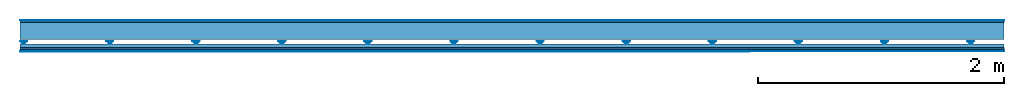
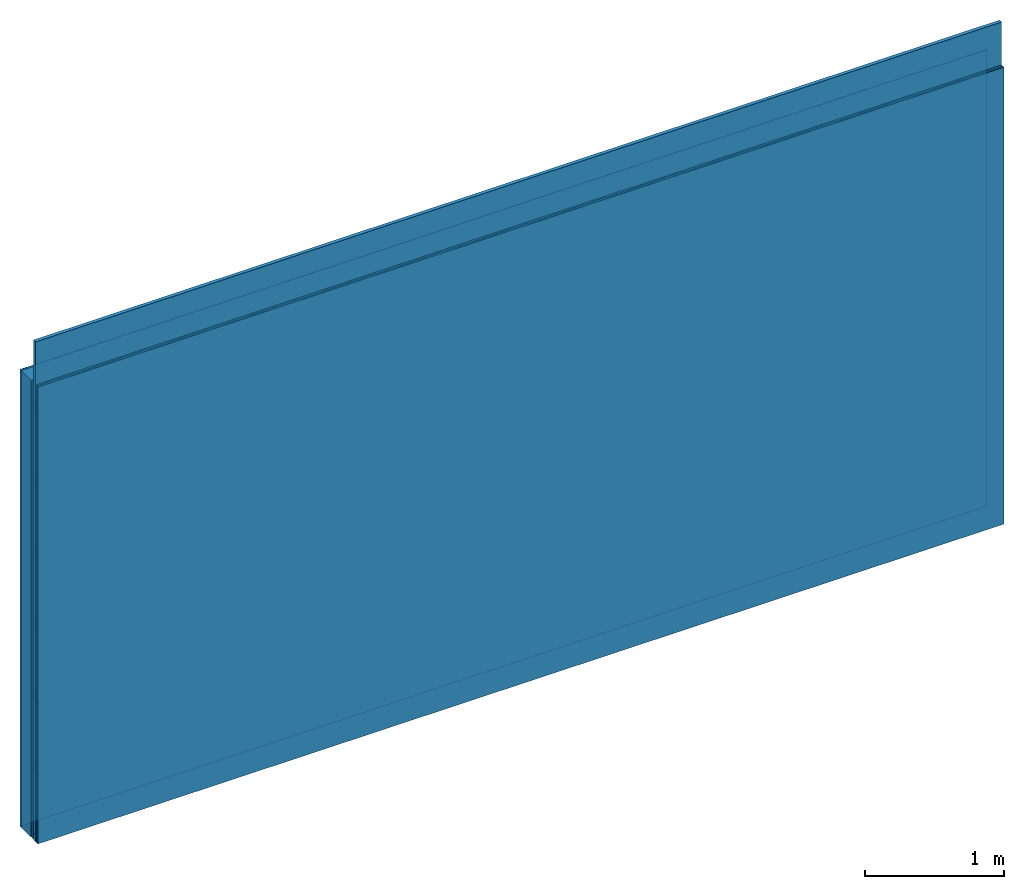
# One storey: 5 plates, 4 members, 1 element without a shape of its own.
"""IFC4 building model written with IfcOpenShell, lengths in metres."""

import ifcopenshell
import ifcopenshell.guid

model = None  # the IFC model being written
_history = None  # IfcOwnerHistory: only IFC2X3 demands one
_inside = {}  # id of a spatial element -> (the spatial element, [elements in it])
_under = {}  # id of a project, library or spatial element -> (it, [spatial elements below it])
_declared = {}  # id of a project -> (the project, [libraries it declares])
_typed = {}  # id of a type object -> (the type object, [elements of that type])
_made_of = {}  # id of a material, layer set ... -> (it, [elements and type objects made of it])


def new_model(schema):
    """Start an empty IFC model of exactly this schema.

    Asked for "IFC4X3", IfcOpenShell would pick the latest addendum, in which some entities
    have other attributes; the version numbers below select the first issue.
    IFC2X3 requires an IfcOwnerHistory on every rooted entity: one is made here for all.
    """
    global model, _history
    if schema == "IFC4X3":
        model = ifcopenshell.file(schema_version=(4, 3, 0, 0))
    else:
        model = ifcopenshell.file(schema=schema)
    _inside.clear()
    _under.clear()
    _declared.clear()
    _typed.clear()
    _made_of.clear()
    _history = None
    if model.schema == "IFC2X3":
        org = make("IfcOrganization", Name="unknown")
        user = make(
            "IfcPersonAndOrganization",
            ThePerson=make("IfcPerson", FamilyName="unknown"),
            TheOrganization=org,
        )
        app = make(
            "IfcApplication",
            ApplicationDeveloper=org,
            Version="unknown",
            ApplicationFullName="unknown",
            ApplicationIdentifier="unknown",
        )
        _history = make(
            "IfcOwnerHistory",
            OwningUser=user,
            OwningApplication=app,
            ChangeAction="ADDED",
            CreationDate=0,
        )
    return model


def make(cls, **values):
    """One entity of the class cls with the attributes given. An attribute that is None is left unset."""
    return model.create_entity(
        cls, **{name: value for name, value in values.items() if value is not None}
    )


def rooted(cls, **values):
    """An entity with a GlobalId (a new one), such as an element, a storey or a relation."""
    return make(cls, GlobalId=ifcopenshell.guid.new(), OwnerHistory=_history, **values)


def si_unit(unit_type, name, prefix=None):
    """IfcSIUnit, for example si_unit("LENGTHUNIT", "METRE", prefix="MILLI")."""
    return make("IfcSIUnit", UnitType=unit_type, Prefix=prefix, Name=name)


def derived_unit(unit_type, elements):
    """IfcDerivedUnit: a product of units, each with its exponent."""
    return make(
        "IfcDerivedUnit",
        Elements=[
            make("IfcDerivedUnitElement", Unit=unit, Exponent=power)
            for unit, power in elements
        ],
        UnitType=unit_type,
    )


def assignment(units):
    """IfcUnitAssignment: the units of a project."""
    return None if units is None else make("IfcUnitAssignment", Units=units)


def point(xyz):
    """IfcCartesianPoint."""
    return None if xyz is None else make("IfcCartesianPoint", Coordinates=xyz)


def direction(xyz):
    """IfcDirection."""
    return None if xyz is None else make("IfcDirection", DirectionRatios=xyz)


def frame(location, z_axis=None, x_axis=None):
    """IfcAxis2Placement3D, a coordinate frame: its origin and axes. An axis left out is left unset."""
    return make(
        "IfcAxis2Placement3D",
        Location=point(location),
        Axis=direction(z_axis),
        RefDirection=direction(x_axis),
    )


def frame_2d(location, x_axis=None):
    """IfcAxis2Placement2D, a coordinate frame in the plane: its origin and x axis."""
    return make(
        "IfcAxis2Placement2D", Location=point(location), RefDirection=direction(x_axis)
    )


def origin():
    """The frame at (0, 0, 0) with its axes left unset."""
    return frame((0.0, 0.0, 0.0))


def origin_with_axes():
    """The frame at (0, 0, 0) with the z axis (0, 0, 1) and the x axis (1, 0, 0) written out."""
    return frame((0.0, 0.0, 0.0), z_axis=(0.0, 0.0, 1.0), x_axis=(1.0, 0.0, 0.0))


def place(relative_to, where):
    """IfcLocalPlacement: puts the frame where relative to a parent placement (None: the world)."""
    return make(
        "IfcLocalPlacement", PlacementRelTo=relative_to, RelativePlacement=where
    )


def context(
    kind, dimensions, precision=None, world=None, true_north=None, identifier=None
):
    """IfcGeometricRepresentationContext, for example the 3D "Model" context."""
    return make(
        "IfcGeometricRepresentationContext",
        ContextIdentifier=identifier,
        ContextType=kind,
        CoordinateSpaceDimension=dimensions,
        Precision=precision,
        WorldCoordinateSystem=world,
        TrueNorth=true_north,
    )


def project(units=None, contexts=None):
    """IfcProject with its units and contexts."""
    return rooted(
        "IfcProject",
        Name="project",
        RepresentationContexts=contexts,
        UnitsInContext=assignment(units),
    )


def spatial(cls, under=None, at=None, **own):
    """A site, building, storey or space (cls), placed at a placement, below another one or the project."""
    s = rooted(cls, ObjectPlacement=at, **own)
    if under is not None:
        _under.setdefault(under.id(), (under, []))[1].append(s)
    return s


def polyline(points):
    """IfcPolyline through the points."""
    return make("IfcPolyline", Points=[point(p) for p in points])


def profile(cls, at=None, kind="AREA", **sizes):
    """A parametric profile (cls). Its sizes go by their IFC names, for example OverallWidth=200.0."""
    return make(cls, ProfileType=kind, Position=at, **sizes)


def rectangle(**sizes):
    """IfcRectangleProfileDef."""
    return profile("IfcRectangleProfileDef", **sizes)


def outline(outer, holes=None, kind="AREA"):
    """IfcArbitraryClosedProfileDef: a profile drawn as a closed curve; with holes, ...WithVoids."""
    if holes is None:
        return make("IfcArbitraryClosedProfileDef", ProfileType=kind, OuterCurve=outer)
    return make(
        "IfcArbitraryProfileDefWithVoids",
        ProfileType=kind,
        OuterCurve=outer,
        InnerCurves=holes,
    )


def extrude(swept, where, along, depth):
    """IfcExtrudedAreaSolid: the profile swept, set in the frame where, extruded along a direction by depth."""
    return make(
        "IfcExtrudedAreaSolid",
        SweptArea=swept,
        Position=where,
        ExtrudedDirection=direction(along),
        Depth=depth,
    )


def shape(context_of_items, identifier, shape_type, items):
    """IfcShapeRepresentation: the items that make up one representation, for example the "Body"."""
    return make(
        "IfcShapeRepresentation",
        ContextOfItems=context_of_items,
        RepresentationIdentifier=identifier,
        RepresentationType=shape_type,
        Items=items,
    )


def material(Name=None, Category=None):
    """IfcMaterial."""
    return make("IfcMaterial", Name=Name, Category=Category)


def layer(
    of_material, thickness, ventilated=None, Name=None, Category=None, Priority=None
):
    """IfcMaterialLayer: one layer of a wall or slab, of a material (None: an air gap)."""
    return make(
        "IfcMaterialLayer",
        Material=of_material,
        LayerThickness=thickness,
        IsVentilated=ventilated,
        Name=Name,
        Category=Category,
        Priority=Priority,
    )


def layer_set(layers, Name=None):
    """IfcMaterialLayerSet."""
    return make("IfcMaterialLayerSet", MaterialLayers=layers, LayerSetName=Name)


def made_of(thing, what):
    """Note that an element or type object is made of a material, layer set ...; save() writes the relation."""
    if what is not None:
        _made_of.setdefault(what.id(), (what, []))[1].append(thing)
    return thing


def type_object(cls, material=None, **own):
    """A type object (cls), such as IfcWallType, which elements share."""
    return made_of(rooted(cls, **own), material)


def element(
    cls,
    number,
    at=None,
    inside=None,
    cuts=None,
    type_object=None,
    material=None,
    context=None,
    identifier="Body",
    shape_type=None,
    held_by="IfcProductDefinitionShape",
    body=None,
    shapes=None,
    **own,
):
    """One element of the class cls, such as IfcWall. Its Tag is "e" and its number.

    at: its placement. inside: the storey or other place that contains it. cuts: it is an
    opening in that element (IfcRelVoidsElement). A single representation is given by context,
    identifier, shape_type and body (its items); several are given by shapes. held_by: the class
    of the entity that holds the representations. save() writes the other relations.
    """
    e = rooted(cls, Tag="e%d" % number, ObjectPlacement=at, **own)
    if body is not None:
        shapes = [shape(context, identifier, shape_type, body)]
    if shapes is not None:
        e.Representation = make(held_by, Representations=shapes)
    if inside is not None:
        _inside.setdefault(inside.id(), (inside, []))[1].append(e)
    if cuts is not None:
        rooted(
            "IfcRelVoidsElement", RelatingBuildingElement=cuts, RelatedOpeningElement=e
        )
    if type_object is not None:
        _typed.setdefault(type_object.id(), (type_object, []))[1].append(e)
    return made_of(e, material)


def aggregate(whole, parts):
    """IfcRelAggregates: a whole, such as a stair, and the parts it consists of."""
    return rooted("IfcRelAggregates", RelatingObject=whole, RelatedObjects=parts)


def save(model, path):
    """Write the relations noted so far, then the file.

    IfcRelAggregates (storeys below a building ...), IfcRelContainedInSpatialStructure (elements
    in a storey), IfcRelDefinesByType, IfcRelAssociatesMaterial and IfcRelDeclares: one each for
    every whole, place, type object, material and project.
    """
    for whole, parts in _under.values():
        aggregate(whole, parts)
    for where, things in _inside.values():
        rooted(
            "IfcRelContainedInSpatialStructure",
            RelatedElements=things,
            RelatingStructure=where,
        )
    for kind, things in _typed.values():
        rooted("IfcRelDefinesByType", RelatedObjects=things, RelatingType=kind)
    for what, things in _made_of.values():
        rooted("IfcRelAssociatesMaterial", RelatedObjects=things, RelatingMaterial=what)
    for by, libraries in _declared.values():
        rooted("IfcRelDeclares", RelatingContext=by, RelatedDefinitions=libraries)
    model.write(path)


model = new_model("IFC4")

# Units and contexts
plan_context = context("Plan", 3, precision=1e-05, world=origin(), true_north=direction((0.0, 1.0)))
model_context = context("Model", 3, precision=1e-05, world=origin(), true_north=direction((0.0, 1.0)))
ifc_project = project(units=[si_unit("LENGTHUNIT", "METRE"), derived_unit("SOUNDPRESSUREUNIT", [(si_unit("PRESSUREUNIT", "PASCAL", prefix="MICRO"), 0)]), si_unit("ENERGYUNIT", "JOULE", prefix="MEGA"), si_unit("MASSUNIT", "GRAM", prefix="KILO"), derived_unit("THERMALTRANSMITTANCEUNIT", [(si_unit("POWERUNIT", "WATT"), 1), (si_unit("AREAUNIT", "SQUARE_METRE"), -1), (si_unit("THERMODYNAMICTEMPERATUREUNIT", "KELVIN"), -1)]), derived_unit("AREADENSITYUNIT", [(si_unit("MASSUNIT", "GRAM", prefix="KILO"), 1), (si_unit("AREAUNIT", "SQUARE_METRE"), -1)]), derived_unit("USERDEFINED", [(si_unit("ENERGYUNIT", "JOULE", prefix="MEGA"), 1), (si_unit("AREAUNIT", "SQUARE_METRE"), -1)])], contexts=[plan_context, model_context])

# Site, building, storey
site = spatial("IfcSite", under=ifc_project)
building_placement = place(None, origin())
building = spatial("IfcBuilding", under=site, at=building_placement)
storey_placement = place(building_placement, origin())
storey = spatial("IfcBuildingStorey", under=building, at=storey_placement)

# Wall, members, plates
ifc_material_1 = material(Category="04.001")
ifc_layer_1 = layer(ifc_material_1, 0.003, Name="Surface")
ifc_material_2 = material(Name="DFH2IR Knauf Diamant hard- plasterboard", Category="03.007")
ifc_layer_2 = layer(ifc_material_2, 0.015, Name="1st layer")
ifc_material_3 = material(Name="of the art")
ifc_layer_3 = layer(ifc_material_3, 0.0, Name="Bond")
ifc_layer_4 = layer(None, 0.14, Name="Support")
ifc_layer_5 = layer(None, 0.036, Name="Coupling")
ifc_layer_6 = layer(None, 0.03, Name="Battens / profiles")
ifc_layer_7 = layer(ifc_material_2, 0.015, Name="Covering 1st layer")
ifc_layer_8 = layer(ifc_material_2, 0.015, Name="Covering 2nd layer")
ifc_layer_9 = layer(ifc_material_1, 0.003, Name="Surface")
ifc_layer_set = layer_set([ifc_layer_1, ifc_layer_2, ifc_layer_3, ifc_layer_4, ifc_layer_5, ifc_layer_6, ifc_layer_7, ifc_layer_8, ifc_layer_9])
wall_type = type_object("IfcWallType", Name="C0382", PredefinedType="NOTDEFINED", material=ifc_layer_set)
wall_placement = place(None, frame((0.0, 0.0, 0.0), z_axis=(0.0, -1.0, 0.0), x_axis=(1.0, 0.0, 0.0)))
wall = element("IfcWall", 1, at=wall_placement, inside=storey, type_object=wall_type, material=ifc_layer_set, Name="Wall #1")
ifc_material_4 = material(Name="Solid timber panel")
member_1_placement = place(wall_placement, origin())
member_1 = element("IfcMember", 2, at=member_1_placement, material=ifc_material_4, Name="Support", context=plan_context, shape_type="SweptSolid", body=[
    extrude(rectangle(XDim=1.0, YDim=0.14, at=frame_2d((0.5, 0.07), x_axis=(1.0, 0.0))), frame((0.0, 4.0, 0.018), z_axis=(0.0, -1.0, 0.0), x_axis=(1.0, 0.0, 0.0)), (0.0, 0.0, 1.0), 4.0),
    extrude(rectangle(XDim=1.0, YDim=0.14, at=frame_2d((0.5, 0.07), x_axis=(1.0, 0.0))), frame((1.0, 4.0, 0.018), z_axis=(0.0, -1.0, 0.0), x_axis=(1.0, 0.0, 0.0)), (0.0, 0.0, 1.0), 4.0),
    extrude(rectangle(XDim=1.0, YDim=0.14, at=frame_2d((0.5, 0.07), x_axis=(1.0, 0.0))), frame((2.0, 4.0, 0.018), z_axis=(0.0, -1.0, 0.0), x_axis=(1.0, 0.0, 0.0)), (0.0, 0.0, 1.0), 4.0),
    extrude(rectangle(XDim=1.0, YDim=0.14, at=frame_2d((0.5, 0.07), x_axis=(1.0, 0.0))), frame((3.0, 4.0, 0.018), z_axis=(0.0, -1.0, 0.0), x_axis=(1.0, 0.0, 0.0)), (0.0, 0.0, 1.0), 4.0),
    extrude(rectangle(XDim=1.0, YDim=0.14, at=frame_2d((0.5, 0.07), x_axis=(1.0, 0.0))), frame((4.0, 4.0, 0.018), z_axis=(0.0, -1.0, 0.0), x_axis=(1.0, 0.0, 0.0)), (0.0, 0.0, 1.0), 4.0),
    extrude(rectangle(XDim=1.0, YDim=0.14, at=frame_2d((0.5, 0.07), x_axis=(1.0, 0.0))), frame((5.0, 4.0, 0.018), z_axis=(0.0, -1.0, 0.0), x_axis=(1.0, 0.0, 0.0)), (0.0, 0.0, 1.0), 4.0),
    extrude(rectangle(XDim=1.0, YDim=0.14, at=frame_2d((0.5, 0.07), x_axis=(1.0, 0.0))), frame((6.0, 4.0, 0.018), z_axis=(0.0, -1.0, 0.0), x_axis=(1.0, 0.0, 0.0)), (0.0, 0.0, 1.0), 4.0),
    extrude(rectangle(XDim=1.0, YDim=0.14, at=frame_2d((0.5, 0.07), x_axis=(1.0, 0.0))), frame((7.0, 4.0, 0.018), z_axis=(0.0, -1.0, 0.0), x_axis=(1.0, 0.0, 0.0)), (0.0, 0.0, 1.0), 4.0),
])
ifc_material_5 = material()
member_2_placement = place(wall_placement, origin())
member_2 = element("IfcMember", 3, at=member_2_placement, material=ifc_material_5, Name="Coupling", context=plan_context, shape_type="SweptSolid", body=[
    extrude(outline(polyline([(0.0, 0.0), (0.06, 0.0), (0.04, 0.02), (0.02, 0.02), (0.0, 0.0)])), frame((0.0, 4.0, 0.174), z_axis=(0.0, -1.0, 0.0), x_axis=(1.0, 0.0, 0.0)), (0.0, 0.0, 1.0), 4.0),
    extrude(outline(polyline([(0.0, 0.0), (0.06, 0.0), (0.04, 0.02), (0.02, 0.02), (0.0, 0.0)])), frame((0.7, 4.0, 0.174), z_axis=(0.0, -1.0, 0.0), x_axis=(1.0, 0.0, 0.0)), (0.0, 0.0, 1.0), 4.0),
    extrude(outline(polyline([(0.0, 0.0), (0.06, 0.0), (0.04, 0.02), (0.02, 0.02), (0.0, 0.0)])), frame((1.4, 4.0, 0.174), z_axis=(0.0, -1.0, 0.0), x_axis=(1.0, 0.0, 0.0)), (0.0, 0.0, 1.0), 4.0),
    extrude(outline(polyline([(0.0, 0.0), (0.06, 0.0), (0.04, 0.02), (0.02, 0.02), (0.0, 0.0)])), frame((2.1, 4.0, 0.174), z_axis=(0.0, -1.0, 0.0), x_axis=(1.0, 0.0, 0.0)), (0.0, 0.0, 1.0), 4.0),
    extrude(outline(polyline([(0.0, 0.0), (0.06, 0.0), (0.04, 0.02), (0.02, 0.02), (0.0, 0.0)])), frame((2.8, 4.0, 0.174), z_axis=(0.0, -1.0, 0.0), x_axis=(1.0, 0.0, 0.0)), (0.0, 0.0, 1.0), 4.0),
    extrude(outline(polyline([(0.0, 0.0), (0.06, 0.0), (0.04, 0.02), (0.02, 0.02), (0.0, 0.0)])), frame((3.5, 4.0, 0.174), z_axis=(0.0, -1.0, 0.0), x_axis=(1.0, 0.0, 0.0)), (0.0, 0.0, 1.0), 4.0),
    extrude(outline(polyline([(0.0, 0.0), (0.06, 0.0), (0.04, 0.02), (0.02, 0.02), (0.0, 0.0)])), frame((4.2, 4.0, 0.174), z_axis=(0.0, -1.0, 0.0), x_axis=(1.0, 0.0, 0.0)), (0.0, 0.0, 1.0), 4.0),
    extrude(outline(polyline([(0.0, 0.0), (0.06, 0.0), (0.04, 0.02), (0.02, 0.02), (0.0, 0.0)])), frame((4.9, 4.0, 0.174), z_axis=(0.0, -1.0, 0.0), x_axis=(1.0, 0.0, 0.0)), (0.0, 0.0, 1.0), 4.0),
    extrude(outline(polyline([(0.0, 0.0), (0.06, 0.0), (0.04, 0.02), (0.02, 0.02), (0.0, 0.0)])), frame((5.6, 4.0, 0.174), z_axis=(0.0, -1.0, 0.0), x_axis=(1.0, 0.0, 0.0)), (0.0, 0.0, 1.0), 4.0),
    extrude(outline(polyline([(0.0, 0.0), (0.06, 0.0), (0.04, 0.02), (0.02, 0.02), (0.0, 0.0)])), frame((6.3, 4.0, 0.174), z_axis=(0.0, -1.0, 0.0), x_axis=(1.0, 0.0, 0.0)), (0.0, 0.0, 1.0), 4.0),
    extrude(outline(polyline([(0.0, 0.0), (0.06, 0.0), (0.04, 0.02), (0.02, 0.02), (0.0, 0.0)])), frame((7.0, 4.0, 0.174), z_axis=(0.0, -1.0, 0.0), x_axis=(1.0, 0.0, 0.0)), (0.0, 0.0, 1.0), 4.0),
    extrude(outline(polyline([(0.0, 0.0), (0.06, 0.0), (0.04, 0.02), (0.02, 0.02), (0.0, 0.0)])), frame((7.7, 4.0, 0.174), z_axis=(0.0, -1.0, 0.0), x_axis=(1.0, 0.0, 0.0)), (0.0, 0.0, 1.0), 4.0),
])
member_3_placement = place(wall_placement, origin())
member_3 = element("IfcMember", 4, at=member_3_placement, material=ifc_material_5, Name="Battens / profiles", context=plan_context, shape_type="SweptSolid", body=[
    extrude(rectangle(XDim=0.06, YDim=0.03, at=frame_2d((0.03, 0.015), x_axis=(1.0, 0.0))), frame((0.0, 0.0, 0.194), z_axis=(1.0, 0.0, 0.0), x_axis=(0.0, 1.0, 0.0)), (0.0, 0.0, 1.0), 8.0),
    extrude(rectangle(XDim=0.06, YDim=0.03, at=frame_2d((0.03, 0.015), x_axis=(1.0, 0.0))), frame((0.0, 0.625, 0.194), z_axis=(1.0, 0.0, 0.0), x_axis=(0.0, 1.0, 0.0)), (0.0, 0.0, 1.0), 8.0),
    extrude(rectangle(XDim=0.06, YDim=0.03, at=frame_2d((0.03, 0.015), x_axis=(1.0, 0.0))), frame((0.0, 1.25, 0.194), z_axis=(1.0, 0.0, 0.0), x_axis=(0.0, 1.0, 0.0)), (0.0, 0.0, 1.0), 8.0),
    extrude(rectangle(XDim=0.06, YDim=0.03, at=frame_2d((0.03, 0.015), x_axis=(1.0, 0.0))), frame((0.0, 1.875, 0.194), z_axis=(1.0, 0.0, 0.0), x_axis=(0.0, 1.0, 0.0)), (0.0, 0.0, 1.0), 8.0),
    extrude(rectangle(XDim=0.06, YDim=0.03, at=frame_2d((0.03, 0.015), x_axis=(1.0, 0.0))), frame((0.0, 2.5, 0.194), z_axis=(1.0, 0.0, 0.0), x_axis=(0.0, 1.0, 0.0)), (0.0, 0.0, 1.0), 8.0),
    extrude(rectangle(XDim=0.06, YDim=0.03, at=frame_2d((0.03, 0.015), x_axis=(1.0, 0.0))), frame((0.0, 3.125, 0.194), z_axis=(1.0, 0.0, 0.0), x_axis=(0.0, 1.0, 0.0)), (0.0, 0.0, 1.0), 8.0),
    extrude(rectangle(XDim=0.06, YDim=0.03, at=frame_2d((0.03, 0.015), x_axis=(1.0, 0.0))), frame((0.0, 3.75, 0.194), z_axis=(1.0, 0.0, 0.0), x_axis=(0.0, 1.0, 0.0)), (0.0, 0.0, 1.0), 8.0),
])
ifc_material_6 = material()
member_4_placement = place(wall_placement, origin())
member_4 = element("IfcMember", 5, at=member_4_placement, material=ifc_material_6, Name="Cavity", context=plan_context, shape_type="SweptSolid", body=[
    extrude(rectangle(XDim=0.565, YDim=0.03, at=frame_2d((0.2825, 0.015), x_axis=(1.0, 0.0))), frame((0.0, 0.06, 0.194), z_axis=(1.0, 0.0, 0.0), x_axis=(0.0, 1.0, 0.0)), (0.0, 0.0, 1.0), 8.0),
    extrude(rectangle(XDim=0.565, YDim=0.03, at=frame_2d((0.2825, 0.015), x_axis=(1.0, 0.0))), frame((0.0, 0.685, 0.194), z_axis=(1.0, 0.0, 0.0), x_axis=(0.0, 1.0, 0.0)), (0.0, 0.0, 1.0), 8.0),
    extrude(rectangle(XDim=0.565, YDim=0.03, at=frame_2d((0.2825, 0.015), x_axis=(1.0, 0.0))), frame((0.0, 1.31, 0.194), z_axis=(1.0, 0.0, 0.0), x_axis=(0.0, 1.0, 0.0)), (0.0, 0.0, 1.0), 8.0),
    extrude(rectangle(XDim=0.565, YDim=0.03, at=frame_2d((0.2825, 0.015), x_axis=(1.0, 0.0))), frame((0.0, 1.935, 0.194), z_axis=(1.0, 0.0, 0.0), x_axis=(0.0, 1.0, 0.0)), (0.0, 0.0, 1.0), 8.0),
    extrude(rectangle(XDim=0.565, YDim=0.03, at=frame_2d((0.2825, 0.015), x_axis=(1.0, 0.0))), frame((0.0, 2.56, 0.194), z_axis=(1.0, 0.0, 0.0), x_axis=(0.0, 1.0, 0.0)), (0.0, 0.0, 1.0), 8.0),
    extrude(rectangle(XDim=0.565, YDim=0.03, at=frame_2d((0.2825, 0.015), x_axis=(1.0, 0.0))), frame((0.0, 3.185, 0.194), z_axis=(1.0, 0.0, 0.0), x_axis=(0.0, 1.0, 0.0)), (0.0, 0.0, 1.0), 8.0),
    extrude(rectangle(XDim=0.565, YDim=0.03, at=frame_2d((0.2825, 0.015), x_axis=(1.0, 0.0))), frame((0.0, 3.81, 0.194), z_axis=(1.0, 0.0, 0.0), x_axis=(0.0, 1.0, 0.0)), (0.0, 0.0, 1.0), 8.0),
])
plate_1_placement = place(wall_placement, origin())
plate_1 = element("IfcPlate", 6, at=plate_1_placement, material=ifc_material_1, Name="Surface", context=plan_context, shape_type="SweptSolid", body=[
    extrude(rectangle(XDim=8.0, YDim=4.0, at=frame_2d((4.0, 2.0), x_axis=(1.0, 0.0))), origin_with_axes(), (0.0, 0.0, 1.0), 0.003),
])
plate_2_placement = place(wall_placement, origin())
plate_2 = element("IfcPlate", 7, at=plate_2_placement, material=ifc_material_2, Name="1st layer", context=plan_context, shape_type="SweptSolid", body=[
    extrude(rectangle(XDim=8.0, YDim=4.0, at=frame_2d((4.0, 2.0), x_axis=(1.0, 0.0))), frame((0.0, 0.0, 0.003), z_axis=(0.0, 0.0, 1.0), x_axis=(1.0, 0.0, 0.0)), (0.0, 0.0, 1.0), 0.015),
])
plate_3_placement = place(wall_placement, origin())
plate_3 = element("IfcPlate", 8, at=plate_3_placement, material=ifc_material_2, Name="Covering 1st layer", context=plan_context, shape_type="SweptSolid", body=[
    extrude(rectangle(XDim=8.0, YDim=4.0, at=frame_2d((4.0, 2.0), x_axis=(1.0, 0.0))), frame((0.0, 0.0, 0.224), z_axis=(0.0, 0.0, 1.0), x_axis=(1.0, 0.0, 0.0)), (0.0, 0.0, 1.0), 0.015),
])
plate_4_placement = place(wall_placement, origin())
plate_4 = element("IfcPlate", 9, at=plate_4_placement, material=ifc_material_2, Name="Covering 2nd layer", context=plan_context, shape_type="SweptSolid", body=[
    extrude(rectangle(XDim=8.0, YDim=4.0, at=frame_2d((4.0, 2.0), x_axis=(1.0, 0.0))), frame((0.0, 0.0, 0.239), z_axis=(0.0, 0.0, 1.0), x_axis=(1.0, 0.0, 0.0)), (0.0, 0.0, 1.0), 0.015),
])
plate_5_placement = place(wall_placement, origin())
plate_5 = element("IfcPlate", 10, at=plate_5_placement, material=ifc_material_1, Name="Surface", context=plan_context, shape_type="SweptSolid", body=[
    extrude(rectangle(XDim=8.0, YDim=4.0, at=frame_2d((4.0, 2.0), x_axis=(1.0, 0.0))), frame((0.0, 0.0, 0.254), z_axis=(0.0, 0.0, 1.0), x_axis=(1.0, 0.0, 0.0)), (0.0, 0.0, 1.0), 0.003),
])
aggregate(wall, [plate_1, plate_2, member_1, member_2, member_3, member_4, plate_3, plate_4, plate_5])

save(model, "model.ifc")
